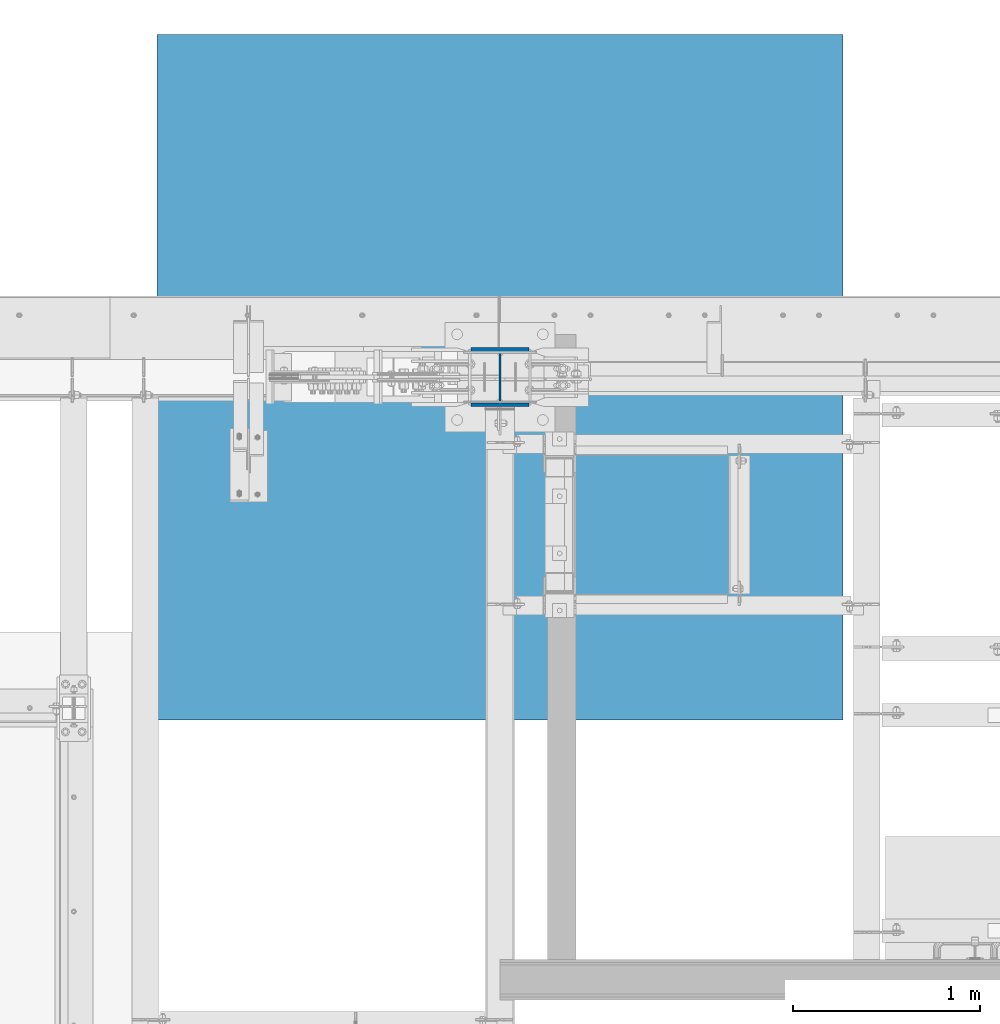
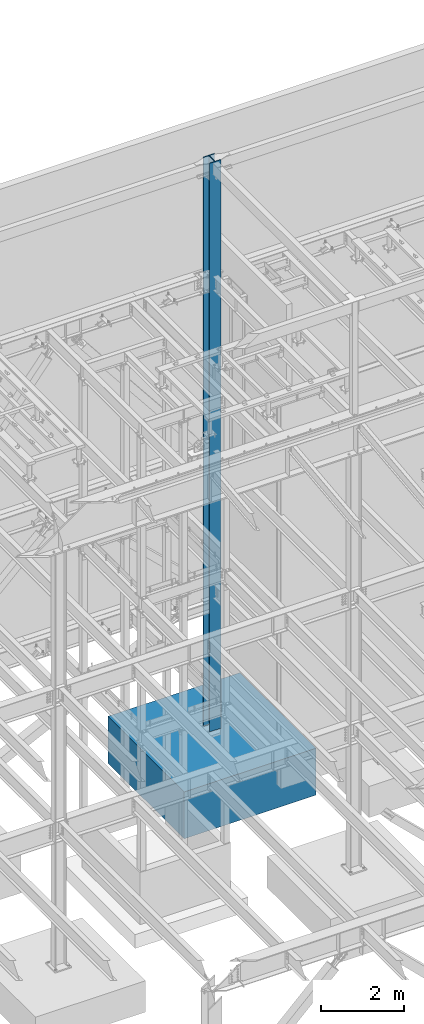
# One storey, part 376 of 1179: 2 columns, 2 elements without a shape of their own.
"""IFC2X3 building model written with IfcOpenShell, lengths in millimetres."""

from ifc_helpers import new_model, si_unit, frame, origin_with_axes, place, context, subcontext, project, spatial, faceted_brep, material, type_object, element, aggregate, save


model = new_model("IFC2X3")

# Units and contexts
model_context = context("Model", 3, precision=1e-05, world=origin_with_axes())
body_context = subcontext(model_context, "Body", "Model", "MODEL_VIEW")
ifc_project = project(units=[si_unit("LENGTHUNIT", "METRE", prefix="MILLI"), si_unit("AREAUNIT", "SQUARE_METRE"), si_unit("VOLUMEUNIT", "CUBIC_METRE"), si_unit("MASSUNIT", "GRAM", prefix="KILO"), si_unit("TIMEUNIT", "SECOND"), si_unit("PLANEANGLEUNIT", "RADIAN"), si_unit("SOLIDANGLEUNIT", "STERADIAN"), si_unit("THERMODYNAMICTEMPERATUREUNIT", "DEGREE_CELSIUS"), si_unit("LUMINOUSINTENSITYUNIT", "LUMEN")], contexts=[model_context])

# Site, building, storey
site_placement = place(None, origin_with_axes())
site = spatial("IfcSite", under=ifc_project, at=site_placement, CompositionType="ELEMENT")
building_placement = place(site_placement, origin_with_axes())
building = spatial("IfcBuilding", under=site, at=building_placement, Name="Undefined", CompositionType="ELEMENT")
storey_placement = place(building_placement, origin_with_axes())
storey = spatial("IfcBuildingStorey", under=building, at=storey_placement, Name="Undefined", CompositionType="ELEMENT", Elevation=0.0)

# Assembly, column
assembly_1_placement = place(storey_placement, origin_with_axes())
assembly_1 = element("IfcElementAssembly", 1, at=assembly_1_placement, inside=storey, Name="FOOTING", AssemblyPlace="NOTDEFINED", PredefinedType="REINFORCEMENT_UNIT")
ifc_material_1 = material(Name="CONCRETE/3000")
column_type_1 = type_object("IfcColumnType", PredefinedType="NOTDEFINED")
column_1_placement = place(assembly_1_placement, frame((16459.2, 41198.8, -1727.2), z_axis=(-1.0, 0.0, 0.0), x_axis=(0.0, 0.0, 1.0)))
column_1 = element("IfcColumn", 2, at=column_1_placement, type_object=column_type_1, material=ifc_material_1, Name="FOOTING", context=body_context, shape_type="Brep", body=[
    faceted_brep([(0.0, 1828.8, -1828.8), (0.0, 1828.8, 1828.8), (1371.6, 1828.8, 1828.8), (1371.6, 1828.8, -1828.8), (0.0, -1828.8, 1828.8), (1371.6, -1828.8, 1828.8), (0.0, -1828.8, -1828.8), (1371.6, -1828.8, -1828.8)], [[[0, 1, 2, 3]], [[1, 4, 5, 2]], [[4, 6, 7, 5]], [[6, 0, 3, 7]], [[5, 7, 3, 2]], [[6, 4, 1, 0]]]),
])
aggregate(assembly_1, [column_1])

assembly_2_placement = place(storey_placement, origin_with_axes())
assembly_2 = element("IfcElementAssembly", 3, at=assembly_2_placement, inside=storey, Name="COLUMN", AssemblyPlace="NOTDEFINED", PredefinedType="RIGID_FRAME")
ifc_material_2 = material(Name="STEEL/A992")
column_type_2 = type_object("IfcColumnType", Name="W12X79", PredefinedType="NOTDEFINED")
column_2_placement = place(assembly_2_placement, frame((16459.2, 41198.8, -355.6), z_axis=(0.0, 1.0, 0.0), x_axis=(0.0, 0.0, 1.0)))
column_2 = element("IfcColumn", 4, at=column_2_placement, type_object=column_type_2, material=ifc_material_2, Name="COLUMN", ObjectType="W12X79", context=body_context, shape_type="Brep", body=[
    faceted_brep([(160.223581529497, -153.987499999999, 157.1625), (160.223581529497, 153.987499999999, 157.1625), (149.225002356772, 153.987499999999, 138.1125), (149.225002356772, 6.35000012494493, 138.1125), (148.995793121516, 6.35000012313685, 137.715499999996), (148.995793121516, -6.34999999999854, 137.715499999996), (149.225002356772, -6.34999999999854, 138.1125), (149.225002356772, -153.987499999999, 138.1125), (16814.8, 153.987500000003, -157.1625), (16814.8, -153.987500000003, -157.1625), (160.223597538519, -153.987499999999, -157.1625), (160.223597538519, 153.987499999999, -157.1625), (16814.8, -153.987500000003, -138.1125), (149.225402461476, -153.987499999999, -138.1125), (16814.8, -6.34999999999854, -138.1125), (149.225402461476, -6.34999999999854, -138.1125), (188.913, -6.34999999999854, 137.715499999996), (188.913, 6.35000008947463, 137.715499999996), (208.49066058208, 6.35000008789211, 131.2871410688), (208.49066058208, -6.34999999999854, 131.2871410688), (212.873373738864, 6.35000008718271, 128.290736246858), (212.873373738864, -6.34999999999854, 128.290736246858), (214.971292158606, 6.35000008606585, 123.413713099926), (214.971292158606, -6.34999999999854, 123.413713099926), (214.132634973196, 6.3500000848835, 118.171264187733), (214.132634973196, -6.34999999999854, 118.171264187733), (210.617956026487, 6.35000008400311, 114.192112472459), (210.617956026487, -6.34999999999854, 114.192112472459), (205.519195059062, 6.35000008370116, 112.712499999996), (205.519195059062, -6.34999999999854, 112.712499999996), (139.700000000001, 6.34999999999854, 112.7125), (147.032309983244, -6.35000007376584, 112.7125), (139.700000000001, 6.34999999999854, -112.7125), (147.032309983244, -6.35000000747095, -112.7125), (205.519195059063, 6.3500000365857, -112.712500000003), (205.519195059063, -6.34999999999854, -112.712500000003), (210.617956026486, 6.35000003621826, -114.192112472468), (210.617956026486, -6.34999999999854, -114.192112472468), (214.132634973195, 6.35000003529422, -118.171264187741), (214.132634973195, -6.34999999999854, -118.171264187741), (214.971292158605, 6.35000003410096, -123.413713099934), (214.971292158605, -6.34999999999854, -123.413713099934), (212.873373738863, 6.35000003300956, -128.290736246865), (212.873373738863, -6.34999999999854, -128.290736246865), (208.49066058208, 6.35000003235837, -131.287141068808), (208.49066058208, -6.34999999999854, -131.287141068808), (188.913, 6.35000003102323, -137.715500000003), (188.913, -6.34999999999854, -137.715500000003), (148.99620123074, 6.35000000162472, -137.715500000003), (148.99620123074, -6.34999999999854, -137.715500000003), (16814.8, 6.34999999999854, -138.1125), (16814.8, 153.987500000003, -138.1125), (149.225402461476, 153.987499999999, -138.1125), (149.225402461477, 6.34999999999854, -138.1125), (16814.8, 6.34999999999854, 138.1125), (16814.8, 153.987500000003, 138.1125), (16814.8, 153.987500000003, 157.1625), (16814.8, -153.987500000003, 157.1625), (16814.8, -153.987500000003, 138.1125), (16814.8, -6.34999999999854, 138.1125)], [[[0, 1, 2, 3, 4, 5, 6, 7]], [[8, 9, 10, 11]], [[9, 12, 13, 10]], [[12, 14, 15, 13]], [[16, 17, 18, 19]], [[19, 18, 20, 21]], [[21, 20, 22, 23]], [[23, 22, 24, 25]], [[25, 24, 26, 27]], [[27, 26, 28, 29]], [[29, 28, 30, 31]], [[32, 33, 31, 30]], [[33, 32, 34, 35]], [[35, 34, 36, 37]], [[37, 36, 38, 39]], [[39, 38, 40, 41]], [[41, 40, 42, 43]], [[43, 42, 44, 45]], [[45, 44, 46, 47]], [[47, 46, 48, 49]], [[50, 51, 52, 53]], [[10, 13, 15, 49, 48, 53, 52, 11]], [[51, 8, 11, 52]], [[50, 54, 55, 56, 57, 58, 59, 14, 12, 9, 8, 51]], [[58, 57, 0, 7]], [[59, 58, 7, 6]], [[16, 19, 21, 23, 25, 27, 29, 31, 33, 35, 37, 39, 41, 43, 45, 47, 49, 15, 14, 59, 6, 5]], [[17, 16, 5, 4]], [[54, 50, 53, 48, 46, 44, 42, 40, 38, 36, 34, 32, 30, 28, 26, 24, 22, 20, 18, 17, 4, 3]], [[55, 54, 3, 2]], [[56, 55, 2, 1]], [[57, 56, 1, 0]]]),
])
aggregate(assembly_2, [column_2])

save(model, "model.ifc")
